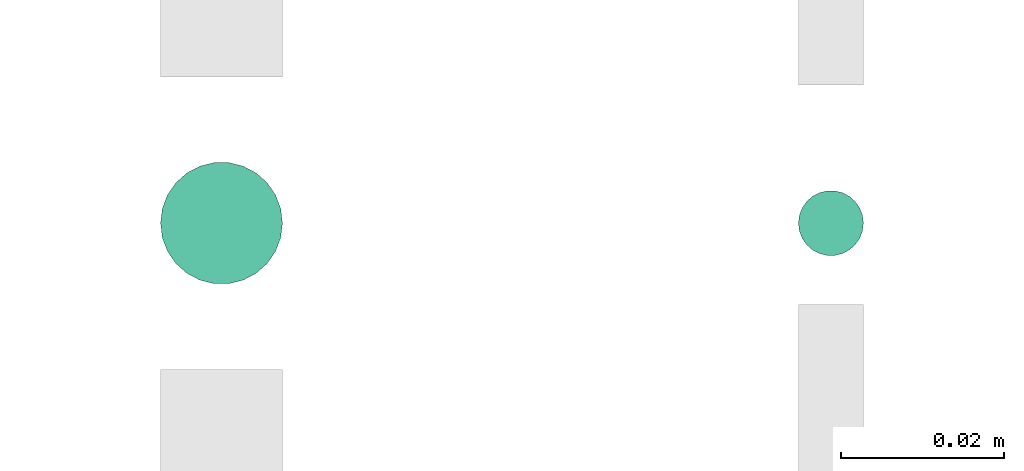
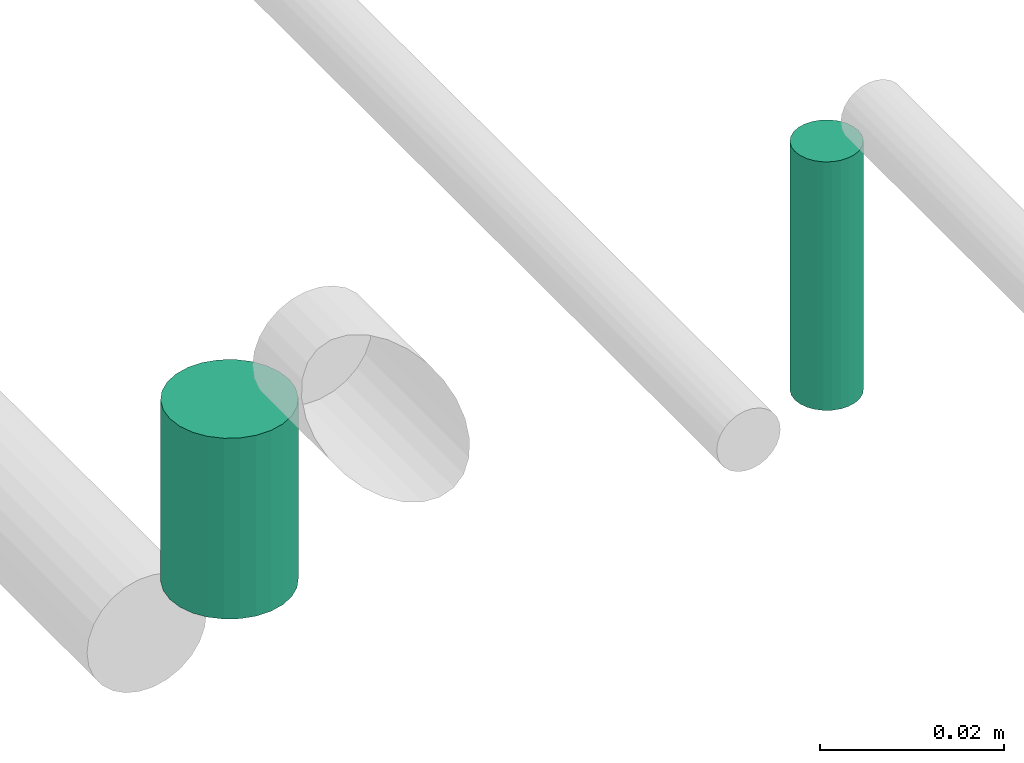
# One storey, part 81 of 89: 2 flow segments.
"""IFC2X3 building model written with IfcOpenShell, lengths in millimetres."""

from ifc_helpers import new_model, entity, si_unit, converted_unit, derived_unit, direction, frame, frame_2d, origin, origin_2d_with_axis, place, context, subcontext, project, spatial, circle, extrude, type_object, element, save


model = new_model("IFC2X3")

# Units and contexts
model_context = context("Model", 3, precision=0.01, world=origin(), true_north=direction((6.12303176911189e-17, 1.0)))
body_context = subcontext(model_context, "Body", "Model", "MODEL_VIEW")
ifc_project = project(units=[si_unit("LENGTHUNIT", "METRE", prefix="MILLI"), si_unit("AREAUNIT", "SQUARE_METRE"), si_unit("VOLUMEUNIT", "CUBIC_METRE"), converted_unit("PLANEANGLEUNIT", "DEGREE", entity("IfcRatioMeasure", 0.0174532925199433), si_unit("PLANEANGLEUNIT", "RADIAN"), dimensions=[0, 0, 0, 0, 0, 0, 0]), si_unit("MASSUNIT", "GRAM", prefix="KILO"), derived_unit("MASSDENSITYUNIT", [(si_unit("MASSUNIT", "GRAM", prefix="KILO"), 1), (si_unit("LENGTHUNIT", "METRE"), -3)]), derived_unit("MOMENTOFINERTIAUNIT", [(si_unit("LENGTHUNIT", "METRE"), 4)]), si_unit("TIMEUNIT", "SECOND"), si_unit("FREQUENCYUNIT", "HERTZ"), si_unit("THERMODYNAMICTEMPERATUREUNIT", "DEGREE_CELSIUS"), derived_unit("THERMALTRANSMITTANCEUNIT", [(si_unit("MASSUNIT", "GRAM", prefix="KILO"), 1), (si_unit("THERMODYNAMICTEMPERATUREUNIT", "KELVIN"), -1), (si_unit("TIMEUNIT", "SECOND"), -3)]), derived_unit("VOLUMETRICFLOWRATEUNIT", [(si_unit("LENGTHUNIT", "METRE"), 3), (si_unit("TIMEUNIT", "SECOND"), -1)]), derived_unit("MASSFLOWRATEUNIT", [(si_unit("MASSUNIT", "GRAM", prefix="KILO"), 1), (si_unit("TIMEUNIT", "SECOND"), -1)]), derived_unit("ROTATIONALFREQUENCYUNIT", [(si_unit("TIMEUNIT", "SECOND"), -1)]), si_unit("ELECTRICCURRENTUNIT", "AMPERE"), si_unit("ELECTRICVOLTAGEUNIT", "VOLT"), si_unit("POWERUNIT", "WATT"), si_unit("FORCEUNIT", "NEWTON", prefix="KILO"), si_unit("ILLUMINANCEUNIT", "LUX"), si_unit("LUMINOUSFLUXUNIT", "LUMEN"), si_unit("LUMINOUSINTENSITYUNIT", "CANDELA"), derived_unit("USERDEFINED", [(si_unit("MASSUNIT", "GRAM", prefix="KILO"), -1), (si_unit("LENGTHUNIT", "METRE"), -2), (si_unit("TIMEUNIT", "SECOND"), 3), (si_unit("LUMINOUSFLUXUNIT", "LUMEN"), 1)]), derived_unit("LINEARVELOCITYUNIT", [(si_unit("LENGTHUNIT", "METRE"), 1), (si_unit("TIMEUNIT", "SECOND"), -1)]), si_unit("PRESSUREUNIT", "PASCAL"), derived_unit("USERDEFINED", [(si_unit("LENGTHUNIT", "METRE"), -2), (si_unit("MASSUNIT", "GRAM", prefix="KILO"), 1), (si_unit("TIMEUNIT", "SECOND"), -2)]), derived_unit("LINEARFORCEUNIT", [(si_unit("MASSUNIT", "GRAM", prefix="KILO"), 1), (si_unit("LENGTHUNIT", "METRE"), 1), (si_unit("TIMEUNIT", "SECOND"), -2), (si_unit("LENGTHUNIT", "METRE"), -1)]), derived_unit("PLANARFORCEUNIT", [(si_unit("MASSUNIT", "GRAM", prefix="KILO"), 1), (si_unit("LENGTHUNIT", "METRE"), 1), (si_unit("TIMEUNIT", "SECOND"), -2), (si_unit("LENGTHUNIT", "METRE"), -2)])], contexts=[model_context])

# Site, building, storey
site_placement = place(None, frame((0.0, -0.00077364408347762, 0.0)))
site = spatial("IfcSite", under=ifc_project, at=site_placement, CompositionType="ELEMENT")
building_placement = place(site_placement, origin())
building = spatial("IfcBuilding", under=site, at=building_placement, CompositionType="ELEMENT")
storey_placement = place(building_placement, frame((0.0, 0.0, 24000.0)))
storey = spatial("IfcBuildingStorey", under=building, at=storey_placement, CompositionType="ELEMENT", Elevation=24000.0)

# Flow segments
pipe_segment_type = type_object("IfcPipeSegmentType", PredefinedType="NOTDEFINED")
flow_segment_1_placement = place(storey_placement, frame((64530.9898186752, 16637.7279049077, 2868.0)))
element("IfcFlowSegment", 1, at=flow_segment_1_placement, inside=storey, type_object=pipe_segment_type, context=body_context, shape_type="SweptSolid", body=[
    extrude(circle(Radius=7.5, at=frame_2d((0.0, -2.16573425859679e-12), x_axis=(1.0, 0.0))), frame((9.09527223591419, 9.09527223591419, 0.0), z_axis=(0.0, 0.0, 1.0), x_axis=(-1.0, 0.0, 0.0)), (0.0, 0.0, 1.0), 24.0000000003497),
])
flow_segment_2_placement = place(storey_placement, frame((64609.4898186752, 16641.2279049078, 2867.0)))
element("IfcFlowSegment", 2, at=flow_segment_2_placement, inside=storey, type_object=pipe_segment_type, context=body_context, shape_type="SweptSolid", body=[
    extrude(circle(Radius=4.0, at=origin_2d_with_axis()), frame((5.59527223591499, 5.59527223591499, 0.0)), (0.0, 0.0, 1.0), 33.0000000000315),
])

save(model, "model.ifc")
